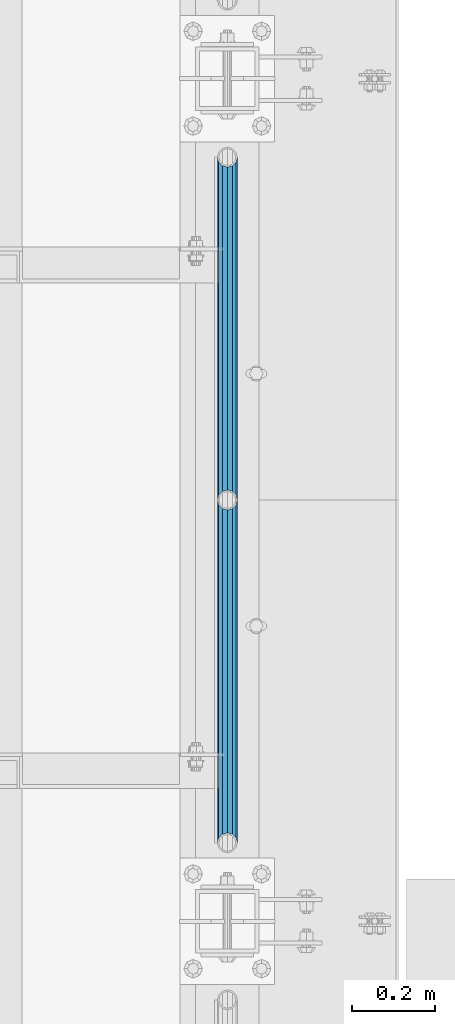
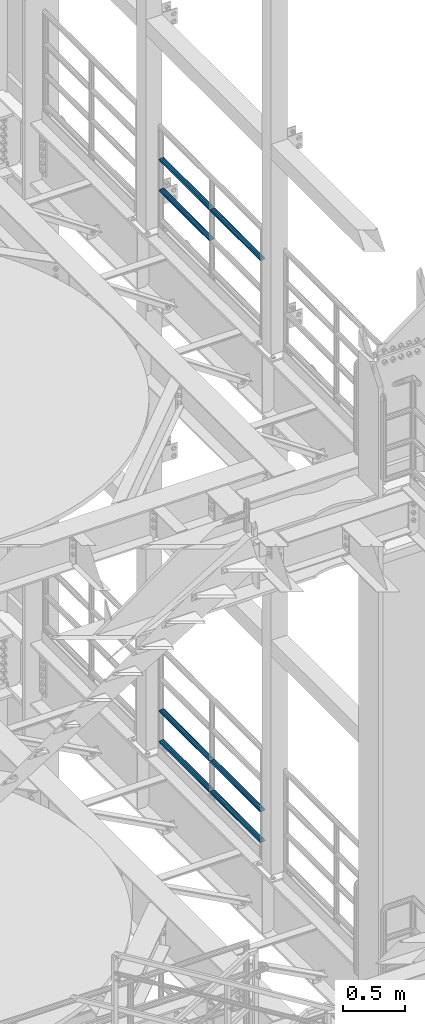
# One storey, part 1264 of 1876: 7 beams, 2 elements without a shape of their own.
"""IFC2X3 building model written with IfcOpenShell, lengths in millimetres."""

from ifc_helpers import new_model, si_unit, frame, origin_with_axes, place, context, subcontext, project, spatial, faceted_brep, material, type_object, element, aggregate, save


model = new_model("IFC2X3")

# Units and contexts
model_context = context("Model", 3, precision=1e-05, world=origin_with_axes())
body_context = subcontext(model_context, "Body", "Model", "MODEL_VIEW")
ifc_project = project(units=[si_unit("LENGTHUNIT", "METRE", prefix="MILLI"), si_unit("AREAUNIT", "SQUARE_METRE"), si_unit("VOLUMEUNIT", "CUBIC_METRE"), si_unit("MASSUNIT", "GRAM", prefix="KILO"), si_unit("TIMEUNIT", "SECOND"), si_unit("PLANEANGLEUNIT", "RADIAN"), si_unit("SOLIDANGLEUNIT", "STERADIAN"), si_unit("THERMODYNAMICTEMPERATUREUNIT", "DEGREE_CELSIUS"), si_unit("LUMINOUSINTENSITYUNIT", "LUMEN")], contexts=[model_context])

# Site, building, storey
site_placement = place(None, origin_with_axes())
site = spatial("IfcSite", under=ifc_project, at=site_placement, CompositionType="ELEMENT")
building_placement = place(site_placement, origin_with_axes())
building = spatial("IfcBuilding", under=site, at=building_placement, Name="Undefined", CompositionType="ELEMENT")
storey_placement = place(building_placement, origin_with_axes())
storey = spatial("IfcBuildingStorey", under=building, at=storey_placement, Name="Undefined", CompositionType="ELEMENT", Elevation=0.0)

# Assembly, beams
assembly_1_placement = place(storey_placement, origin_with_axes())
assembly_1 = element("IfcElementAssembly", 1, at=assembly_1_placement, inside=storey, Name="RAIL", AssemblyPlace="NOTDEFINED", PredefinedType="RIGID_FRAME")
ifc_material = material()
beam_type = type_object("IfcBeamType", Name="PIPE1-1/2SCH40", PredefinedType="NOTDEFINED")
beam_1_placement = place(assembly_1_placement, frame((7620.0, -1524.0, 13776.325), z_axis=(0.0, 0.0, -1.0), x_axis=(0.0, 1.0, 0.0)))
beam_1 = element("IfcBeam", 2, at=beam_1_placement, type_object=beam_type, material=ifc_material, Name="RAIL", ObjectType="PIPE1-1/2SCH40", context=body_context, shape_type="Brep", body=[
    faceted_brep([(0.0, 24.1299999999992, 0.0), (12.0650000000064, 20.8971929933177, -12.0649999999987), (12.0650000000064, 20.8971929933177, 12.0649999999987), (12.0650000000064, -20.8971929933177, 12.0649999999987), (12.0650000000064, -20.8971929933177, -12.0649999999987), (0.0, -24.1299999999992, 0.0), (20.8971929933249, -12.0650000000005, 20.8971929933177), (20.8971929933249, -12.0650000000005, 15.8661214311796), (15.2545715621445, -17.7076214311801, 10.2235000000001), (12.5151929933249, -20.4470000000001, 0.0), (15.2545715621445, -17.7076214311801, -10.2235000000001), (20.8971929933249, -12.0650000000005, -15.8661214311796), (20.8971929933249, -12.0650000000005, -20.8971929933177), (24.1300000000063, 0.0, -20.4470000000001), (24.1300000000063, 0.0, -24.130000000001), (21.3906214311868, -10.2235000000001, -17.7076214311819), (21.3906214311868, 10.2235000000001, -17.7076214311819), (20.8971929933249, 12.0650000000005, -15.8661214311796), (20.8971929933249, 12.0650000000005, -20.8971929933177), (15.2545715621445, 17.7076214311801, -10.2235000000001), (12.5151929933249, 20.4470000000001, 0.0), (15.2545715621445, 17.7076214311801, 10.2235000000001), (20.8971929933249, 12.0650000000005, 15.8661214311796), (20.8971929933249, 12.0650000000005, 20.8971929933177), (21.3906214311868, 10.2235000000001, 17.7076214311819), (24.1300000000064, 0.0, 20.4470000000001), (24.1300000000064, 0.0, 24.130000000001), (21.3906214311868, -10.2235000000001, 17.7076214311819), (826.77, 24.1300000000001, 0.0), (814.705, 20.8971929933186, -12.0649999999987), (805.872807006681, 12.0649999999996, -20.8971929933177), (826.77, -24.1300000000001, 0.0), (814.705, -20.8971929933186, -12.0649999999987), (814.705, -20.8971929933186, 12.0649999999987), (805.872807006681, -12.0649999999996, 20.8971929933177), (805.872807006681, -12.0649999999996, -20.8971929933177), (802.640000000001, 0.0, -24.130000000001), (805.379378568819, 10.2235000000001, -17.7076214311819), (802.640000000001, 0.0, -20.4470000000001), (805.872807006683, 12.0649999999996, -15.8661214311796), (805.872807006683, -12.0649999999996, -15.8661214311796), (805.379378568819, -10.2235000000001, -17.7076214311819), (811.515428437862, -17.7076214311801, -10.2235000000001), (814.254807006682, -20.4470000000001, 0.0), (811.515428437862, -17.7076214311801, 10.2235000000001), (805.872807006683, -12.0649999999996, 15.8661214311796), (805.379378568819, -10.2235000000001, 17.7076214311819), (802.640000000001, 0.0, 20.4470000000001), (802.640000000001, 0.0, 24.130000000001), (805.872807006681, 12.0649999999996, 20.8971929933177), (814.705, 20.8971929933186, 12.0649999999987), (805.872807006683, 12.0649999999996, 15.8661214311796), (811.515428437862, 17.7076214311801, 10.2235000000001), (814.254807006682, 20.4470000000001, 0.0), (811.515428437862, 17.7076214311801, -10.2235000000001), (805.379378568819, 10.2235000000001, 17.7076214311819)], [[[0, 1, 2]], [[3, 4, 5]], [[6, 7, 8, 9, 10, 11, 12, 4, 3]], [[13, 14, 12, 11, 15]], [[16, 17, 18, 14, 13]], [[2, 1, 18, 17, 19, 20, 21, 22, 23]], [[23, 22, 24, 25, 26]], [[26, 25, 27, 7, 6]], [[1, 0, 28, 29]], [[18, 1, 29, 30]], [[31, 32, 33]], [[6, 3, 33, 34]], [[3, 5, 31, 33]], [[5, 4, 32, 31]], [[4, 12, 35, 32]], [[12, 14, 36, 35]], [[14, 18, 30, 36]], [[37, 38, 36, 30, 39]], [[40, 35, 36, 38, 41]], [[33, 32, 35, 40, 42, 43, 44, 45, 34]], [[34, 45, 46, 47, 48]], [[26, 6, 34, 48]], [[2, 23, 49, 50]], [[23, 26, 48, 49]], [[0, 2, 50, 28]], [[28, 50, 29]], [[49, 51, 52, 53, 54, 39, 30, 29, 50]], [[48, 47, 55, 51, 49]], [[25, 24, 55, 47]], [[55, 24, 22, 21, 52, 51]], [[21, 20, 53, 52]], [[20, 19, 54, 53]], [[19, 17, 16, 37, 39, 54]], [[16, 13, 38, 37]], [[13, 15, 41, 38]], [[41, 15, 11, 10, 42, 40]], [[10, 9, 43, 42]], [[9, 8, 44, 43]], [[8, 7, 27, 46, 45, 44]], [[27, 25, 47, 46]]]),
])
beam_2_placement = place(assembly_1_placement, frame((7620.0, -2350.77, 14081.125), z_axis=(0.0, 0.0, -1.0), x_axis=(0.0, 1.0, 0.0)))
beam_2 = element("IfcBeam", 3, at=beam_2_placement, type_object=beam_type, material=ifc_material, Name="RAIL", ObjectType="PIPE1-1/2SCH40", context=body_context, shape_type="Brep", body=[
    faceted_brep([(0.0, 24.1299999999992, 0.0), (12.0650000000064, 20.8971929933177, -12.0649999999987), (12.0650000000064, 20.8971929933177, 12.0649999999987), (12.0650000000064, -20.8971929933177, 12.0649999999987), (12.0650000000064, -20.8971929933177, -12.0649999999987), (0.0, -24.1299999999992, 0.0), (20.8971929933249, -12.0650000000005, 20.8971929933177), (20.8971929933249, -12.0650000000005, 15.8661214311796), (15.2545715621445, -17.7076214311801, 10.2235000000001), (12.5151929933249, -20.4470000000001, 0.0), (15.2545715621445, -17.7076214311801, -10.2235000000001), (20.8971929933249, -12.0650000000005, -15.8661214311796), (20.8971929933249, -12.0650000000005, -20.8971929933177), (24.1300000000063, 0.0, -20.4470000000001), (24.1300000000063, 0.0, -24.130000000001), (21.3906214311868, -10.2235000000001, -17.7076214311819), (21.3906214311868, 10.2235000000001, -17.7076214311819), (20.8971929933249, 12.0650000000005, -15.8661214311796), (20.8971929933249, 12.0650000000005, -20.8971929933177), (15.2545715621445, 17.7076214311801, -10.2235000000001), (12.5151929933249, 20.4470000000001, 0.0), (15.2545715621445, 17.7076214311801, 10.2235000000001), (20.8971929933249, 12.0650000000005, 15.8661214311796), (20.8971929933249, 12.0650000000005, 20.8971929933177), (21.3906214311868, 10.2235000000001, 17.7076214311819), (24.1300000000064, 0.0, 20.4470000000001), (24.1300000000064, 0.0, 24.130000000001), (21.3906214311868, -10.2235000000001, 17.7076214311819), (826.77, 24.1300000000001, 0.0), (814.705, 20.8971929933186, -12.0649999999987), (805.872807006681, 12.0649999999996, -20.8971929933177), (826.77, -24.1300000000001, 0.0), (814.705, -20.8971929933186, -12.0649999999987), (814.705, -20.8971929933186, 12.0649999999987), (805.872807006681, -12.0649999999996, 20.8971929933177), (805.872807006681, -12.0649999999996, -20.8971929933177), (802.640000000001, 0.0, -24.130000000001), (805.379378568819, 10.2235000000001, -17.7076214311819), (802.640000000001, 0.0, -20.4470000000001), (805.872807006683, 12.0649999999996, -15.8661214311796), (805.872807006683, -12.0649999999996, -15.8661214311796), (805.379378568819, -10.2235000000001, -17.7076214311819), (811.515428437862, -17.7076214311801, -10.2235000000001), (814.254807006682, -20.4470000000001, 0.0), (811.515428437862, -17.7076214311801, 10.2235000000001), (805.872807006683, -12.0649999999996, 15.8661214311796), (805.379378568819, -10.2235000000001, 17.7076214311819), (802.640000000001, 0.0, 20.4470000000001), (802.640000000001, 0.0, 24.130000000001), (805.872807006681, 12.0649999999996, 20.8971929933177), (814.705, 20.8971929933186, 12.0649999999987), (805.872807006683, 12.0649999999996, 15.8661214311796), (811.515428437862, 17.7076214311801, 10.2235000000001), (814.254807006682, 20.4470000000001, 0.0), (811.515428437862, 17.7076214311801, -10.2235000000001), (805.379378568819, 10.2235000000001, 17.7076214311819)], [[[0, 1, 2]], [[3, 4, 5]], [[6, 7, 8, 9, 10, 11, 12, 4, 3]], [[13, 14, 12, 11, 15]], [[16, 17, 18, 14, 13]], [[2, 1, 18, 17, 19, 20, 21, 22, 23]], [[23, 22, 24, 25, 26]], [[26, 25, 27, 7, 6]], [[1, 0, 28, 29]], [[18, 1, 29, 30]], [[31, 32, 33]], [[6, 3, 33, 34]], [[3, 5, 31, 33]], [[5, 4, 32, 31]], [[4, 12, 35, 32]], [[12, 14, 36, 35]], [[14, 18, 30, 36]], [[37, 38, 36, 30, 39]], [[40, 35, 36, 38, 41]], [[33, 32, 35, 40, 42, 43, 44, 45, 34]], [[34, 45, 46, 47, 48]], [[26, 6, 34, 48]], [[2, 23, 49, 50]], [[23, 26, 48, 49]], [[0, 2, 50, 28]], [[28, 50, 29]], [[49, 51, 52, 53, 54, 39, 30, 29, 50]], [[48, 47, 55, 51, 49]], [[25, 24, 55, 47]], [[55, 24, 22, 21, 52, 51]], [[21, 20, 53, 52]], [[20, 19, 54, 53]], [[19, 17, 16, 37, 39, 54]], [[16, 13, 38, 37]], [[13, 15, 41, 38]], [[41, 15, 11, 10, 42, 40]], [[10, 9, 43, 42]], [[9, 8, 44, 43]], [[8, 7, 27, 46, 45, 44]], [[27, 25, 47, 46]]]),
])
beam_3_placement = place(assembly_1_placement, frame((7620.0, -1524.0, 14081.125), z_axis=(0.0, 0.0, -1.0), x_axis=(0.0, 1.0, 0.0)))
beam_3 = element("IfcBeam", 4, at=beam_3_placement, type_object=beam_type, material=ifc_material, Name="RAIL", ObjectType="PIPE1-1/2SCH40", context=body_context, shape_type="Brep", body=[
    faceted_brep([(0.0, 24.1299999999992, 0.0), (12.0650000000064, 20.8971929933177, -12.0649999999987), (12.0650000000064, 20.8971929933177, 12.0649999999987), (12.0650000000064, -20.8971929933177, 12.0649999999987), (12.0650000000064, -20.8971929933177, -12.0649999999987), (0.0, -24.1299999999992, 0.0), (20.8971929933249, -12.0650000000005, 20.8971929933177), (20.8971929933249, -12.0650000000005, 15.8661214311796), (15.2545715621445, -17.7076214311801, 10.2235000000001), (12.5151929933249, -20.4470000000001, 0.0), (15.2545715621445, -17.7076214311801, -10.2235000000001), (20.8971929933249, -12.0650000000005, -15.8661214311796), (20.8971929933249, -12.0650000000005, -20.8971929933177), (24.1300000000063, 0.0, -20.4470000000001), (24.1300000000063, 0.0, -24.130000000001), (21.3906214311868, -10.2235000000001, -17.7076214311819), (21.3906214311868, 10.2235000000001, -17.7076214311819), (20.8971929933249, 12.0650000000005, -15.8661214311796), (20.8971929933249, 12.0650000000005, -20.8971929933177), (15.2545715621445, 17.7076214311801, -10.2235000000001), (12.5151929933249, 20.4470000000001, 0.0), (15.2545715621445, 17.7076214311801, 10.2235000000001), (20.8971929933249, 12.0650000000005, 15.8661214311796), (20.8971929933249, 12.0650000000005, 20.8971929933177), (21.3906214311868, 10.2235000000001, 17.7076214311819), (24.1300000000064, 0.0, 20.4470000000001), (24.1300000000064, 0.0, 24.130000000001), (21.3906214311868, -10.2235000000001, 17.7076214311819), (826.77, 24.1300000000001, 0.0), (814.705, 20.8971929933186, -12.0649999999987), (805.872807006681, 12.0649999999996, -20.8971929933177), (826.77, -24.1300000000001, 0.0), (814.705, -20.8971929933186, -12.0649999999987), (814.705, -20.8971929933186, 12.0649999999987), (805.872807006681, -12.0649999999996, 20.8971929933177), (805.872807006681, -12.0649999999996, -20.8971929933177), (802.640000000001, 0.0, -24.130000000001), (805.379378568819, 10.2235000000001, -17.7076214311819), (802.640000000001, 0.0, -20.4470000000001), (805.872807006683, 12.0649999999996, -15.8661214311796), (805.872807006683, -12.0649999999996, -15.8661214311796), (805.379378568819, -10.2235000000001, -17.7076214311819), (811.515428437862, -17.7076214311801, -10.2235000000001), (814.254807006682, -20.4470000000001, 0.0), (811.515428437862, -17.7076214311801, 10.2235000000001), (805.872807006683, -12.0649999999996, 15.8661214311796), (805.379378568819, -10.2235000000001, 17.7076214311819), (802.640000000001, 0.0, 20.4470000000001), (802.640000000001, 0.0, 24.130000000001), (805.872807006681, 12.0649999999996, 20.8971929933177), (814.705, 20.8971929933186, 12.0649999999987), (805.872807006683, 12.0649999999996, 15.8661214311796), (811.515428437862, 17.7076214311801, 10.2235000000001), (814.254807006682, 20.4470000000001, 0.0), (811.515428437862, 17.7076214311801, -10.2235000000001), (805.379378568819, 10.2235000000001, 17.7076214311819)], [[[0, 1, 2]], [[3, 4, 5]], [[6, 7, 8, 9, 10, 11, 12, 4, 3]], [[13, 14, 12, 11, 15]], [[16, 17, 18, 14, 13]], [[2, 1, 18, 17, 19, 20, 21, 22, 23]], [[23, 22, 24, 25, 26]], [[26, 25, 27, 7, 6]], [[1, 0, 28, 29]], [[18, 1, 29, 30]], [[31, 32, 33]], [[6, 3, 33, 34]], [[3, 5, 31, 33]], [[5, 4, 32, 31]], [[4, 12, 35, 32]], [[12, 14, 36, 35]], [[14, 18, 30, 36]], [[37, 38, 36, 30, 39]], [[40, 35, 36, 38, 41]], [[33, 32, 35, 40, 42, 43, 44, 45, 34]], [[34, 45, 46, 47, 48]], [[26, 6, 34, 48]], [[2, 23, 49, 50]], [[23, 26, 48, 49]], [[0, 2, 50, 28]], [[28, 50, 29]], [[49, 51, 52, 53, 54, 39, 30, 29, 50]], [[48, 47, 55, 51, 49]], [[25, 24, 55, 47]], [[55, 24, 22, 21, 52, 51]], [[21, 20, 53, 52]], [[20, 19, 54, 53]], [[19, 17, 16, 37, 39, 54]], [[16, 13, 38, 37]], [[13, 15, 41, 38]], [[41, 15, 11, 10, 42, 40]], [[10, 9, 43, 42]], [[9, 8, 44, 43]], [[8, 7, 27, 46, 45, 44]], [[27, 25, 47, 46]]]),
])
aggregate(assembly_1, [beam_1, beam_2, beam_3])

assembly_2_placement = place(storey_placement, origin_with_axes())
assembly_2 = element("IfcElementAssembly", 5, at=assembly_2_placement, inside=storey, Name="RAIL", AssemblyPlace="NOTDEFINED", PredefinedType="RIGID_FRAME")
beam_4_placement = place(assembly_2_placement, frame((7620.0, -1524.0, 8315.325), z_axis=(0.0, 0.0, 1.0), x_axis=(0.0, -1.0, 0.0)))
beam_4 = element("IfcBeam", 6, at=beam_4_placement, type_object=beam_type, material=ifc_material, Name="RAIL", ObjectType="PIPE1-1/2SCH40", context=body_context, shape_type="Brep", body=[
    faceted_brep([(805.872807006681, -12.0649999999996, 20.8971929933177), (805.872807006683, -12.0649999999996, 15.8661214311796), (805.379378568819, -10.2235000000001, 17.7076214311819), (802.640000000001, 0.0, 20.4470000000001), (802.640000000001, 0.0, 24.130000000001), (805.379378568819, 10.2235000000001, 17.7076214311819), (805.872807006683, 12.0649999999996, 15.8661214311796), (805.872807006681, 12.0649999999996, 20.8971929933177), (826.77, 24.1300000000001, 0.0), (814.705, 20.8971929933186, 12.0649999999987), (814.705, 20.8971929933186, -12.0649999999987), (811.515428437862, 17.7076214311801, 10.2235000000001), (814.254807006682, 20.4470000000001, 0.0), (811.515428437862, 17.7076214311801, -10.2235000000001), (805.872807006683, 12.0649999999996, -15.8661214311796), (805.872807006681, 12.0649999999996, -20.8971929933177), (805.379378568819, 10.2235000000001, -17.7076214311819), (802.640000000001, 0.0, -20.4470000000001), (802.640000000001, 0.0, -24.130000000001), (805.872807006683, -12.0649999999996, -15.8661214311796), (805.872807006681, -12.0649999999996, -20.8971929933177), (805.379378568819, -10.2235000000001, -17.7076214311819), (826.77, -24.1300000000001, 0.0), (814.705, -20.8971929933186, -12.0649999999987), (814.705, -20.8971929933186, 12.0649999999987), (811.515428437862, -17.7076214311801, -10.2235000000001), (814.254807006682, -20.4470000000001, 0.0), (811.515428437862, -17.7076214311801, 10.2235000000001), (12.0650000000064, -20.8971929933177, -12.0649999999987), (20.8971929933249, -12.0650000000005, -20.8971929933177), (0.0, 24.1299999999992, 0.0), (12.0650000000064, 20.8971929933177, -12.0649999999987), (12.0650000000064, 20.8971929933177, 12.0649999999987), (20.8971929933249, 12.0650000000005, 20.8971929933177), (24.1300000000064, 0.0, 24.130000000001), (20.8971929933249, 12.0650000000005, -20.8971929933177), (24.1300000000063, 0.0, -24.130000000001), (24.1300000000063, 0.0, -20.4470000000001), (20.8971929933249, -12.0650000000005, -15.8661214311796), (21.3906214311868, -10.2235000000001, -17.7076214311819), (21.3906214311868, 10.2235000000001, -17.7076214311819), (20.8971929933249, 12.0650000000005, -15.8661214311796), (15.2545715621445, 17.7076214311801, -10.2235000000001), (12.5151929933249, 20.4470000000001, 0.0), (15.2545715621445, 17.7076214311801, 10.2235000000001), (20.8971929933249, 12.0650000000005, 15.8661214311796), (21.3906214311868, 10.2235000000001, 17.7076214311819), (24.1300000000064, 0.0, 20.4470000000001), (21.3906214311868, -10.2235000000001, 17.7076214311819), (20.8971929933249, -12.0650000000005, 15.8661214311796), (20.8971929933249, -12.0650000000005, 20.8971929933177), (12.0650000000064, -20.8971929933177, 12.0649999999987), (0.0, -24.1299999999992, 0.0), (15.2545715621445, -17.7076214311801, 10.2235000000001), (12.5151929933249, -20.4470000000001, 0.0), (15.2545715621445, -17.7076214311801, -10.2235000000001)], [[[0, 1, 2, 3, 4]], [[4, 3, 5, 6, 7]], [[8, 9, 10]], [[7, 6, 11, 12, 13, 14, 15, 10, 9]], [[16, 17, 18, 15, 14]], [[19, 20, 18, 17, 21]], [[22, 23, 24]], [[24, 23, 20, 19, 25, 26, 27, 1, 0]], [[28, 29, 20, 23]], [[30, 31, 32]], [[33, 34, 4, 7]], [[32, 33, 7, 9]], [[30, 32, 9, 8]], [[31, 30, 8, 10]], [[35, 31, 10, 15]], [[36, 35, 15, 18]], [[29, 36, 18, 20]], [[37, 36, 29, 38, 39]], [[40, 41, 35, 36, 37]], [[32, 31, 35, 41, 42, 43, 44, 45, 33]], [[33, 45, 46, 47, 34]], [[34, 47, 48, 49, 50]], [[34, 50, 0, 4]], [[50, 51, 24, 0]], [[51, 52, 22, 24]], [[52, 28, 23, 22]], [[51, 28, 52]], [[50, 49, 53, 54, 55, 38, 29, 28, 51]], [[55, 54, 26, 25]], [[21, 39, 38, 55, 25, 19]], [[37, 39, 21, 17]], [[40, 37, 17, 16]], [[42, 41, 40, 16, 14, 13]], [[43, 42, 13, 12]], [[44, 43, 12, 11]], [[5, 46, 45, 44, 11, 6]], [[47, 46, 5, 3]], [[48, 47, 3, 2]], [[53, 49, 48, 2, 1, 27]], [[54, 53, 27, 26]]]),
])
beam_5_placement = place(assembly_2_placement, frame((7620.0, -697.230000000001, 8315.325), z_axis=(0.0, 0.0, 1.0), x_axis=(0.0, -1.0, 0.0)))
beam_5 = element("IfcBeam", 7, at=beam_5_placement, type_object=beam_type, material=ifc_material, Name="RAIL", ObjectType="PIPE1-1/2SCH40", context=body_context, shape_type="Brep", body=[
    faceted_brep([(805.872807006681, -12.0649999999996, 20.8971929933177), (805.872807006683, -12.0649999999996, 15.8661214311796), (805.379378568819, -10.2235000000001, 17.7076214311819), (802.640000000001, 0.0, 20.4470000000001), (802.640000000001, 0.0, 24.130000000001), (805.379378568819, 10.2235000000001, 17.7076214311819), (805.872807006683, 12.0649999999996, 15.8661214311796), (805.872807006681, 12.0649999999996, 20.8971929933177), (826.77, 24.1300000000001, 0.0), (814.705, 20.8971929933186, 12.0649999999987), (814.705, 20.8971929933186, -12.0649999999987), (811.515428437862, 17.7076214311801, 10.2235000000001), (814.254807006682, 20.4470000000001, 0.0), (811.515428437862, 17.7076214311801, -10.2235000000001), (805.872807006683, 12.0649999999996, -15.8661214311796), (805.872807006681, 12.0649999999996, -20.8971929933177), (805.379378568819, 10.2235000000001, -17.7076214311819), (802.640000000001, 0.0, -20.4470000000001), (802.640000000001, 0.0, -24.130000000001), (805.872807006683, -12.0649999999996, -15.8661214311796), (805.872807006681, -12.0649999999996, -20.8971929933177), (805.379378568819, -10.2235000000001, -17.7076214311819), (826.77, -24.1300000000001, 0.0), (814.705, -20.8971929933186, -12.0649999999987), (814.705, -20.8971929933186, 12.0649999999987), (811.515428437862, -17.7076214311801, -10.2235000000001), (814.254807006682, -20.4470000000001, 0.0), (811.515428437862, -17.7076214311801, 10.2235000000001), (12.0650000000064, -20.8971929933177, -12.0649999999987), (20.8971929933249, -12.0650000000005, -20.8971929933177), (0.0, 24.1299999999992, 0.0), (12.0650000000064, 20.8971929933177, -12.0649999999987), (12.0650000000064, 20.8971929933177, 12.0649999999987), (20.8971929933249, 12.0650000000005, 20.8971929933177), (24.1300000000064, 0.0, 24.130000000001), (20.8971929933249, 12.0650000000005, -20.8971929933177), (24.1300000000063, 0.0, -24.130000000001), (24.1300000000063, 0.0, -20.4470000000001), (20.8971929933249, -12.0650000000005, -15.8661214311796), (21.3906214311868, -10.2235000000001, -17.7076214311819), (21.3906214311868, 10.2235000000001, -17.7076214311819), (20.8971929933249, 12.0650000000005, -15.8661214311796), (15.2545715621445, 17.7076214311801, -10.2235000000001), (12.5151929933249, 20.4470000000001, 0.0), (15.2545715621445, 17.7076214311801, 10.2235000000001), (20.8971929933249, 12.0650000000005, 15.8661214311796), (21.3906214311868, 10.2235000000001, 17.7076214311819), (24.1300000000064, 0.0, 20.4470000000001), (21.3906214311868, -10.2235000000001, 17.7076214311819), (20.8971929933249, -12.0650000000005, 15.8661214311796), (20.8971929933249, -12.0650000000005, 20.8971929933177), (12.0650000000064, -20.8971929933177, 12.0649999999987), (0.0, -24.1299999999992, 0.0), (15.2545715621445, -17.7076214311801, 10.2235000000001), (12.5151929933249, -20.4470000000001, 0.0), (15.2545715621445, -17.7076214311801, -10.2235000000001)], [[[0, 1, 2, 3, 4]], [[4, 3, 5, 6, 7]], [[8, 9, 10]], [[7, 6, 11, 12, 13, 14, 15, 10, 9]], [[16, 17, 18, 15, 14]], [[19, 20, 18, 17, 21]], [[22, 23, 24]], [[24, 23, 20, 19, 25, 26, 27, 1, 0]], [[28, 29, 20, 23]], [[30, 31, 32]], [[33, 34, 4, 7]], [[32, 33, 7, 9]], [[30, 32, 9, 8]], [[31, 30, 8, 10]], [[35, 31, 10, 15]], [[36, 35, 15, 18]], [[29, 36, 18, 20]], [[37, 36, 29, 38, 39]], [[40, 41, 35, 36, 37]], [[32, 31, 35, 41, 42, 43, 44, 45, 33]], [[33, 45, 46, 47, 34]], [[34, 47, 48, 49, 50]], [[34, 50, 0, 4]], [[50, 51, 24, 0]], [[51, 52, 22, 24]], [[52, 28, 23, 22]], [[51, 28, 52]], [[50, 49, 53, 54, 55, 38, 29, 28, 51]], [[55, 54, 26, 25]], [[21, 39, 38, 55, 25, 19]], [[37, 39, 21, 17]], [[40, 37, 17, 16]], [[42, 41, 40, 16, 14, 13]], [[43, 42, 13, 12]], [[44, 43, 12, 11]], [[5, 46, 45, 44, 11, 6]], [[47, 46, 5, 3]], [[48, 47, 3, 2]], [[53, 49, 48, 2, 1, 27]], [[54, 53, 27, 26]]]),
])
beam_6_placement = place(assembly_2_placement, frame((7620.0, -2350.77, 8620.125), z_axis=(0.0, 0.0, -1.0), x_axis=(0.0, 1.0, 0.0)))
beam_6 = element("IfcBeam", 8, at=beam_6_placement, type_object=beam_type, material=ifc_material, Name="RAIL", ObjectType="PIPE1-1/2SCH40", context=body_context, shape_type="Brep", body=[
    faceted_brep([(0.0, 24.1299999999992, 0.0), (12.0650000000064, 20.8971929933177, -12.0649999999987), (12.0650000000064, 20.8971929933177, 12.0649999999987), (12.0650000000064, -20.8971929933177, 12.0649999999987), (12.0650000000064, -20.8971929933177, -12.0649999999987), (0.0, -24.1299999999992, 0.0), (20.8971929933249, -12.0650000000005, 20.8971929933177), (20.8971929933249, -12.0650000000005, 15.8661214311796), (15.2545715621445, -17.7076214311801, 10.2235000000001), (12.5151929933249, -20.4470000000001, 0.0), (15.2545715621445, -17.7076214311801, -10.2235000000001), (20.8971929933249, -12.0650000000005, -15.8661214311796), (20.8971929933249, -12.0650000000005, -20.8971929933177), (24.1300000000063, 0.0, -20.4470000000001), (24.1300000000063, 0.0, -24.130000000001), (21.3906214311868, -10.2235000000001, -17.7076214311819), (21.3906214311868, 10.2235000000001, -17.7076214311819), (20.8971929933249, 12.0650000000005, -15.8661214311796), (20.8971929933249, 12.0650000000005, -20.8971929933177), (15.2545715621445, 17.7076214311801, -10.2235000000001), (12.5151929933249, 20.4470000000001, 0.0), (15.2545715621445, 17.7076214311801, 10.2235000000001), (20.8971929933249, 12.0650000000005, 15.8661214311796), (20.8971929933249, 12.0650000000005, 20.8971929933177), (21.3906214311868, 10.2235000000001, 17.7076214311819), (24.1300000000064, 0.0, 20.4470000000001), (24.1300000000064, 0.0, 24.130000000001), (21.3906214311868, -10.2235000000001, 17.7076214311819), (826.77, 24.1300000000001, 0.0), (814.705, 20.8971929933186, -12.0649999999987), (805.872807006681, 12.0649999999996, -20.8971929933177), (826.77, -24.1300000000001, 0.0), (814.705, -20.8971929933186, -12.0649999999987), (814.705, -20.8971929933186, 12.0649999999987), (805.872807006681, -12.0649999999996, 20.8971929933177), (805.872807006681, -12.0649999999996, -20.8971929933177), (802.640000000001, 0.0, -24.130000000001), (805.379378568819, 10.2235000000001, -17.7076214311819), (802.640000000001, 0.0, -20.4470000000001), (805.872807006683, 12.0649999999996, -15.8661214311796), (805.872807006683, -12.0649999999996, -15.8661214311796), (805.379378568819, -10.2235000000001, -17.7076214311819), (811.515428437862, -17.7076214311801, -10.2235000000001), (814.254807006682, -20.4470000000001, 0.0), (811.515428437862, -17.7076214311801, 10.2235000000001), (805.872807006683, -12.0649999999996, 15.8661214311796), (805.379378568819, -10.2235000000001, 17.7076214311819), (802.640000000001, 0.0, 20.4470000000001), (802.640000000001, 0.0, 24.130000000001), (805.872807006681, 12.0649999999996, 20.8971929933177), (814.705, 20.8971929933186, 12.0649999999987), (805.872807006683, 12.0649999999996, 15.8661214311796), (811.515428437862, 17.7076214311801, 10.2235000000001), (814.254807006682, 20.4470000000001, 0.0), (811.515428437862, 17.7076214311801, -10.2235000000001), (805.379378568819, 10.2235000000001, 17.7076214311819)], [[[0, 1, 2]], [[3, 4, 5]], [[6, 7, 8, 9, 10, 11, 12, 4, 3]], [[13, 14, 12, 11, 15]], [[16, 17, 18, 14, 13]], [[2, 1, 18, 17, 19, 20, 21, 22, 23]], [[23, 22, 24, 25, 26]], [[26, 25, 27, 7, 6]], [[1, 0, 28, 29]], [[18, 1, 29, 30]], [[31, 32, 33]], [[6, 3, 33, 34]], [[3, 5, 31, 33]], [[5, 4, 32, 31]], [[4, 12, 35, 32]], [[12, 14, 36, 35]], [[14, 18, 30, 36]], [[37, 38, 36, 30, 39]], [[40, 35, 36, 38, 41]], [[33, 32, 35, 40, 42, 43, 44, 45, 34]], [[34, 45, 46, 47, 48]], [[26, 6, 34, 48]], [[2, 23, 49, 50]], [[23, 26, 48, 49]], [[0, 2, 50, 28]], [[28, 50, 29]], [[49, 51, 52, 53, 54, 39, 30, 29, 50]], [[48, 47, 55, 51, 49]], [[25, 24, 55, 47]], [[55, 24, 22, 21, 52, 51]], [[21, 20, 53, 52]], [[20, 19, 54, 53]], [[19, 17, 16, 37, 39, 54]], [[16, 13, 38, 37]], [[13, 15, 41, 38]], [[41, 15, 11, 10, 42, 40]], [[10, 9, 43, 42]], [[9, 8, 44, 43]], [[8, 7, 27, 46, 45, 44]], [[27, 25, 47, 46]]]),
])
beam_7_placement = place(assembly_2_placement, frame((7620.0, -1524.0, 8620.125), z_axis=(0.0, 0.0, -1.0), x_axis=(0.0, 1.0, 0.0)))
beam_7 = element("IfcBeam", 9, at=beam_7_placement, type_object=beam_type, material=ifc_material, Name="RAIL", ObjectType="PIPE1-1/2SCH40", context=body_context, shape_type="Brep", body=[
    faceted_brep([(0.0, 24.1299999999992, 0.0), (12.0650000000064, 20.8971929933177, -12.0649999999987), (12.0650000000064, 20.8971929933177, 12.0649999999987), (12.0650000000064, -20.8971929933177, 12.0649999999987), (12.0650000000064, -20.8971929933177, -12.0649999999987), (0.0, -24.1299999999992, 0.0), (20.8971929933249, -12.0650000000005, 20.8971929933177), (20.8971929933249, -12.0650000000005, 15.8661214311796), (15.2545715621445, -17.7076214311801, 10.2235000000001), (12.5151929933249, -20.4470000000001, 0.0), (15.2545715621445, -17.7076214311801, -10.2235000000001), (20.8971929933249, -12.0650000000005, -15.8661214311796), (20.8971929933249, -12.0650000000005, -20.8971929933177), (24.1300000000063, 0.0, -20.4470000000001), (24.1300000000063, 0.0, -24.130000000001), (21.3906214311868, -10.2235000000001, -17.7076214311819), (21.3906214311868, 10.2235000000001, -17.7076214311819), (20.8971929933249, 12.0650000000005, -15.8661214311796), (20.8971929933249, 12.0650000000005, -20.8971929933177), (15.2545715621445, 17.7076214311801, -10.2235000000001), (12.5151929933249, 20.4470000000001, 0.0), (15.2545715621445, 17.7076214311801, 10.2235000000001), (20.8971929933249, 12.0650000000005, 15.8661214311796), (20.8971929933249, 12.0650000000005, 20.8971929933177), (21.3906214311868, 10.2235000000001, 17.7076214311819), (24.1300000000064, 0.0, 20.4470000000001), (24.1300000000064, 0.0, 24.130000000001), (21.3906214311868, -10.2235000000001, 17.7076214311819), (826.77, 24.1300000000001, 0.0), (814.705, 20.8971929933186, -12.0649999999987), (805.872807006681, 12.0649999999996, -20.8971929933177), (826.77, -24.1300000000001, 0.0), (814.705, -20.8971929933186, -12.0649999999987), (814.705, -20.8971929933186, 12.0649999999987), (805.872807006681, -12.0649999999996, 20.8971929933177), (805.872807006681, -12.0649999999996, -20.8971929933177), (802.640000000001, 0.0, -24.130000000001), (805.379378568819, 10.2235000000001, -17.7076214311819), (802.640000000001, 0.0, -20.4470000000001), (805.872807006683, 12.0649999999996, -15.8661214311796), (805.872807006683, -12.0649999999996, -15.8661214311796), (805.379378568819, -10.2235000000001, -17.7076214311819), (811.515428437862, -17.7076214311801, -10.2235000000001), (814.254807006682, -20.4470000000001, 0.0), (811.515428437862, -17.7076214311801, 10.2235000000001), (805.872807006683, -12.0649999999996, 15.8661214311796), (805.379378568819, -10.2235000000001, 17.7076214311819), (802.640000000001, 0.0, 20.4470000000001), (802.640000000001, 0.0, 24.130000000001), (805.872807006681, 12.0649999999996, 20.8971929933177), (814.705, 20.8971929933186, 12.0649999999987), (805.872807006683, 12.0649999999996, 15.8661214311796), (811.515428437862, 17.7076214311801, 10.2235000000001), (814.254807006682, 20.4470000000001, 0.0), (811.515428437862, 17.7076214311801, -10.2235000000001), (805.379378568819, 10.2235000000001, 17.7076214311819)], [[[0, 1, 2]], [[3, 4, 5]], [[6, 7, 8, 9, 10, 11, 12, 4, 3]], [[13, 14, 12, 11, 15]], [[16, 17, 18, 14, 13]], [[2, 1, 18, 17, 19, 20, 21, 22, 23]], [[23, 22, 24, 25, 26]], [[26, 25, 27, 7, 6]], [[1, 0, 28, 29]], [[18, 1, 29, 30]], [[31, 32, 33]], [[6, 3, 33, 34]], [[3, 5, 31, 33]], [[5, 4, 32, 31]], [[4, 12, 35, 32]], [[12, 14, 36, 35]], [[14, 18, 30, 36]], [[37, 38, 36, 30, 39]], [[40, 35, 36, 38, 41]], [[33, 32, 35, 40, 42, 43, 44, 45, 34]], [[34, 45, 46, 47, 48]], [[26, 6, 34, 48]], [[2, 23, 49, 50]], [[23, 26, 48, 49]], [[0, 2, 50, 28]], [[28, 50, 29]], [[49, 51, 52, 53, 54, 39, 30, 29, 50]], [[48, 47, 55, 51, 49]], [[25, 24, 55, 47]], [[55, 24, 22, 21, 52, 51]], [[21, 20, 53, 52]], [[20, 19, 54, 53]], [[19, 17, 16, 37, 39, 54]], [[16, 13, 38, 37]], [[13, 15, 41, 38]], [[41, 15, 11, 10, 42, 40]], [[10, 9, 43, 42]], [[9, 8, 44, 43]], [[8, 7, 27, 46, 45, 44]], [[27, 25, 47, 46]]]),
])
aggregate(assembly_2, [beam_4, beam_5, beam_6, beam_7])

save(model, "model.ifc")
